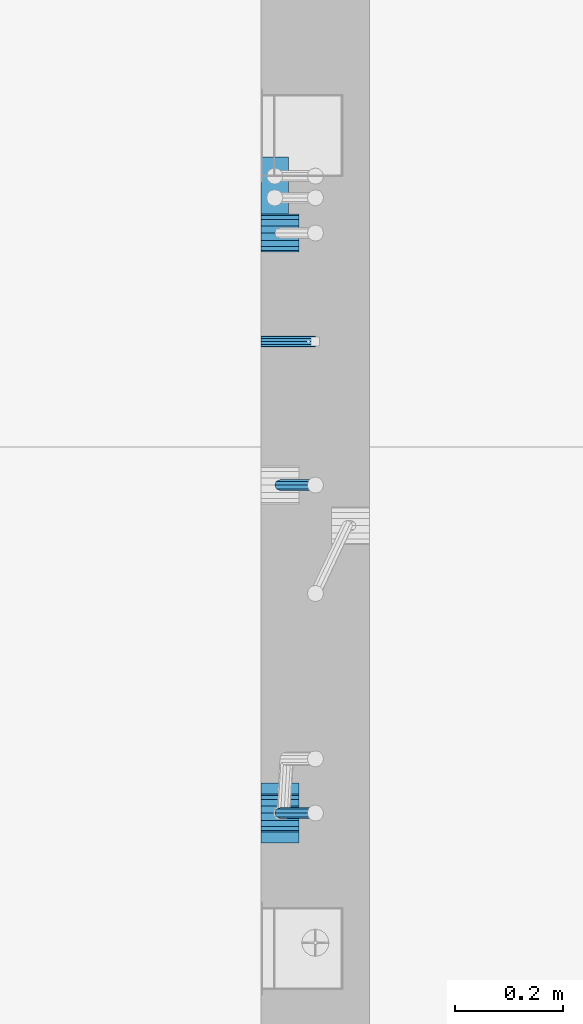
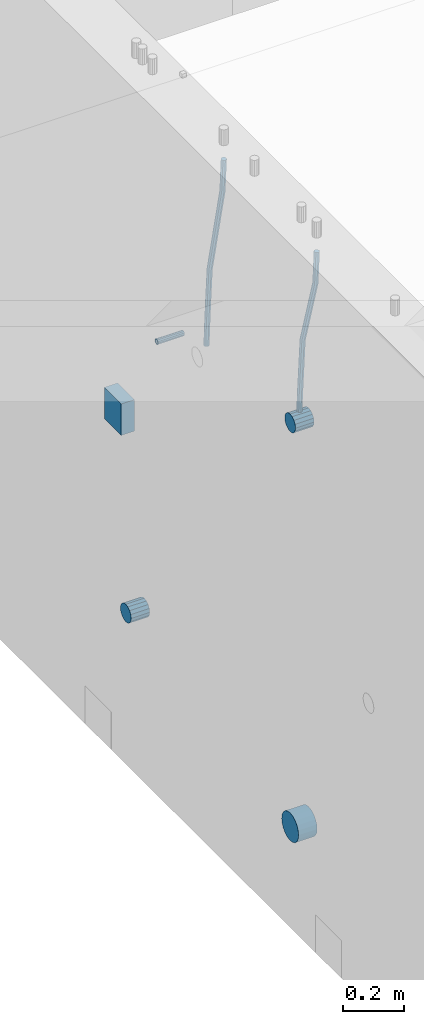
# One storey, part 140 of 341: 7 beams, 2 elements without a shape of their own.
"""IFC2X3 building model written with IfcOpenShell, lengths in millimetres."""

from ifc_helpers import new_model, si_unit, frame, origin_with_axes, place, context, subcontext, project, spatial, faceted_brep, material, type_object, element, aggregate, save


model = new_model("IFC2X3")

# Units and contexts
model_context = context("Model", 3, precision=1e-05, world=origin_with_axes())
body_context = subcontext(model_context, "Body", "Model", "MODEL_VIEW")
ifc_project = project(units=[si_unit("LENGTHUNIT", "METRE", prefix="MILLI"), si_unit("AREAUNIT", "SQUARE_METRE"), si_unit("VOLUMEUNIT", "CUBIC_METRE"), si_unit("MASSUNIT", "GRAM", prefix="KILO"), si_unit("TIMEUNIT", "SECOND"), si_unit("PLANEANGLEUNIT", "RADIAN"), si_unit("SOLIDANGLEUNIT", "STERADIAN"), si_unit("THERMODYNAMICTEMPERATUREUNIT", "DEGREE_CELSIUS"), si_unit("LUMINOUSINTENSITYUNIT", "LUMEN")], contexts=[model_context])

# Site, building, storey
site_placement = place(None, origin_with_axes())
site = spatial("IfcSite", under=ifc_project, at=site_placement, CompositionType="ELEMENT")
building_placement = place(site_placement, origin_with_axes())
building = spatial("IfcBuilding", under=site, at=building_placement, CompositionType="ELEMENT")
storey_placement = place(building_placement, origin_with_axes())
storey = spatial("IfcBuildingStorey", under=building, at=storey_placement, Name="5", CompositionType="ELEMENT", Elevation=0.0)

# Assemblies, beams
assembly_1_placement = place(storey_placement, origin_with_axes())
assembly_1 = element("IfcElementAssembly", 1, at=assembly_1_placement, inside=storey, AssemblyPlace="NOTDEFINED", PredefinedType="REINFORCEMENT_UNIT")
assembly_2_placement = place(assembly_1_placement, origin_with_axes())
assembly_2 = element("IfcElementAssembly", 2, at=assembly_2_placement, Name="Steel Assembly", AssemblyPlace="NOTDEFINED", PredefinedType="RIGID_FRAME")
ifc_material_1 = material(Name="STEEL/Steel_Undefined")
beam_type_1 = type_object("IfcBeamType", PredefinedType="NOTDEFINED")
beam_1_placement = place(assembly_2_placement, frame((21710.0, 11374.9997839591, 95555.0), z_axis=(0.0, 1.0, 0.0), x_axis=(1.0, 0.0, 0.0)))
beam_1 = element("IfcBeam", 3, at=beam_1_placement, type_object=beam_type_1, material=ifc_material_1, Name="M16", context=body_context, shape_type="Brep", body=[
    faceted_brep([(0.0, -8.49999999999272, -1.45519152283669e-11), (0.0, -7.36121593215648, 4.24999999998545), (100.000000000262, -7.36121593215648, 4.24999999998545), (100.000000000262, -8.49999999999272, -1.45519152283669e-11), (0.0, -4.24999999998545, 7.36121593216376), (100.000000000262, -4.24999999998545, 7.36121593216376), (0.0, 1.45519152283669e-11, 8.49999999998545), (100.000000000262, 1.45519152283669e-11, 8.49999999998545), (0.0, 4.25000000001455, 7.36121593216376), (100.000000000262, 4.25000000001455, 7.36121593216376), (0.0, 7.36121593217104, 4.24999999998545), (100.000000000262, 7.36121593217104, 4.24999999998545), (0.0, 8.50000000000728, 0.0), (100.000000000262, 8.50000000000728, 0.0), (0.0, 7.36121593217104, -4.25000000001455), (100.000000000262, 7.36121593217104, -4.25000000001455), (0.0, 4.25000000000728, -7.36121593219286), (100.000000000262, 4.25000000000728, -7.36121593219286), (0.0, 7.27595761418343e-12, -8.5), (100.000000000262, 7.27595761418343e-12, -8.5), (0.0, -4.24999999999272, -7.36121593217831), (100.000000000262, -4.24999999999272, -7.36121593217831), (0.0, -7.36121593215648, -4.25), (100.000000000262, -7.36121593215648, -4.25), (0.0, -10.4999999999927, -1.45519152283669e-11), (0.0, -9.09326673972828, -5.25000000001455), (100.000000000262, -9.09326673972828, -5.25000000001455), (100.000000000262, -10.4999999999927, -1.45519152283669e-11), (0.0, -5.24999999998545, -9.09326673974283), (100.000000000262, -5.24999999998545, -9.09326673974283), (0.0, 7.27595761418343e-12, -10.5), (100.000000000262, 7.27595761418343e-12, -10.5), (0.0, 5.25000000001455, -9.09326673975738), (100.000000000262, 5.25000000001455, -9.09326673975738), (0.0, 9.09326673975011, -5.25000000001455), (100.000000000262, 9.09326673975011, -5.25000000001455), (0.0, 10.5000000000073, -1.45519152283669e-11), (100.000000000262, 10.5000000000073, -1.45519152283669e-11), (0.0, 9.09326673975011, 5.25), (100.000000000262, 9.09326673975011, 5.25), (0.0, 5.25000000000728, 9.09326673972828), (100.000000000262, 5.25000000000728, 9.09326673972828), (0.0, 1.45519152283669e-11, 10.4999999999854), (100.000000000262, 1.45519152283669e-11, 10.4999999999854), (0.0, -5.24999999999272, 9.09326673972828), (100.000000000262, -5.24999999999272, 9.09326673972828), (0.0, -9.09326673972828, 5.24999999998545), (100.000000000262, -9.09326673972828, 5.24999999998545)], [[[0, 1, 2, 3]], [[1, 4, 5, 2]], [[4, 6, 7, 5]], [[6, 8, 9, 7]], [[8, 10, 11, 9]], [[10, 12, 13, 11]], [[12, 14, 15, 13]], [[14, 16, 17, 15]], [[16, 18, 19, 17]], [[18, 20, 21, 19]], [[20, 22, 23, 21]], [[22, 0, 3, 23]], [[24, 25, 26, 27]], [[25, 28, 29, 26]], [[28, 30, 31, 29]], [[30, 32, 33, 31]], [[32, 34, 35, 33]], [[34, 36, 37, 35]], [[36, 38, 39, 37]], [[38, 40, 41, 39]], [[40, 42, 43, 41]], [[42, 44, 45, 43]], [[44, 46, 47, 45]], [[46, 24, 27, 47]], [[29, 31, 33, 35, 37, 39, 41, 43, 45, 47, 27, 26], [5, 7, 9, 11, 13, 15, 17, 19, 21, 23, 3, 2]], [[46, 44, 42, 40, 38, 36, 34, 32, 30, 28, 25, 24], [22, 20, 18, 16, 14, 12, 10, 8, 6, 4, 1, 0]]]),
])
aggregate(assembly_2, [beam_1])
ifc_material_2 = material()
beam_type_2 = type_object("IfcBeamType", Name="D20", PredefinedType="NOTDEFINED")
beam_2_placement = place(assembly_1_placement, frame((21744.9999977209, 10504.9999999961, 95795.0), z_axis=(0.999642804629538, 0.000205762999925497, -0.0267249099901003), x_axis=(0.0267249109941254, -4.30000210532798e-08, 0.999642825779465)))
beam_2 = element("IfcBeam", 4, at=beam_2_placement, type_object=beam_type_2, material=ifc_material_2, Name="JM20", ObjectType="D20", context=body_context, shape_type="Brep", body=[
    faceted_brep([(0.0, -10.0, 0.0), (-4.19531716033816e-08, -7.07106781186667, -7.07106781187031), (60.3902110151248, -7.07106779622882, -7.07106780570393), (60.3902110191848, -9.99999998436397, 6.15546014159918e-09), (0.0, 0.0, -10.0), (60.3902110119234, 1.56360329128802e-08, -9.99999999383726), (4.196772351861e-08, 7.07106781186303, -7.07106781186667), (60.3902110114723, 7.07106782750088, -7.07106780570757), (0.0, 10.0, 0.0), (60.3902110140189, 10.000000015636, 6.15909812040627e-09), (4.196772351861e-08, 7.07106781185939, 7.07106781185939), (60.3902110180788, 7.07106782750088, 7.07106781802213), (0.0, 0.0, 10.0), (60.3902110212803, 1.56378519022837e-08, 10.0000000061627), (-4.19531716033816e-08, -7.07106781187031, 7.07106781185939), (60.3902110217459, -7.07106779622882, 7.07106781802213), (61.0636251037213, -7.07106779605601, -7.07106780563481), (60.991799419251, -9.99999998403655, 6.21366780251265e-09), (61.0933608038758, 1.58179318532348e-08, -9.99999999376814), (61.0635953103047, 7.07106782767551, -7.07106780563481), (60.9917724058905, 10.0000000159635, 6.21366780251265e-09), (60.9199467214348, 7.07106782763913, 7.07106781808034), (60.8902110212803, 1.57651811605319e-08, 10.0000000062137), (60.919976514866, -7.07106779609421, 7.07106781808034), (61.736900248201, -7.07106495914195, -7.05738882369405), (61.5932788141945, -9.99999744984598, 0.0122201548947487), (61.7963655163912, 2.97800033877138e-06, -9.98571699394597), (61.7368406711612, 7.07107066446406, -7.05738942880998), (61.5931945595512, 10.0000025499758, 0.0122192991293559), (61.4495731255302, 7.07107005927173, 7.0818282777218), (61.3901078573399, 2.12213126360439e-06, 10.0101564479701), (61.4496327025554, -7.07106556433428, 7.08182888283409), (278.724613209561, -7.07015065944142, -2.64883307638229), (278.580991775569, -9.99908315014545, 4.42077590220288), (278.78407847778, 0.000917277700864361, -5.57716124663784), (278.724553632535, 7.07198496416277, -2.64883368149822), (278.580907520925, 10.0009168496781, 4.42077504644112), (278.437286086933, 7.07198435897226, 11.4903840250299), (278.377820818714, 0.000916421833608183, 14.4187121952782), (278.437345663944, -7.07015126463193, 11.4903846301422), (280.757740145142, -7.07014209265617, -2.60752588292962), (279.97914288567, -9.99907725889352, 4.4491822438722), (281.080112136013, 0.000926952270674519, -5.53051255744504), (280.757417718196, 7.07199352984026, -2.60753182838744), (279.978686905117, 10.0009227393621, 4.44917383572465), (279.200089645645, 7.0719875731229, 11.5058819625192), (278.877717654759, 0.000918528197871638, 14.4288686370419), (279.200412072576, -7.07014804937353, 11.5058879079807), (282.750959243713, -7.07005867588668, -2.20455064874841), (281.349849970706, -9.99901989442333, 4.72630231008952), (283.331077414448, 0.00102115578738449, -5.07542798552822), (282.750379126286, 7.07207693582313, -2.20460869228191), (281.349029560777, 10.0009800885819, 4.72622022413998), (279.947920287756, 7.07201887003976, 11.6570731829706), (279.367802117034, 0.000939038367505418, 14.5279505197614), (279.948500405197, -7.07011674167188, 11.6571312265078), (490.42756900216, -7.06136735270411, 39.782068138702), (489.026459729153, -9.99032857123893, 46.7129210975436), (491.007687172896, 0.00971247897177818, 36.9111908019222), (490.426988884734, 7.08076825901298, 39.7820100951685), (489.02563931921, 10.0096714117662, 46.7128390115868), (487.624530046218, 7.08071019322961, 53.6436919704247), (487.044411875468, 0.0096303615537181, 56.5145693072081), (487.625110163644, -7.06142541848567, 53.6437500139618), (491.139936791646, -7.06133753991526, 39.9260897251916), (490.366909417033, -9.99027247305094, 46.9839239327412), (491.497771635157, 0.00973298914141196, 37.0102726846344), (491.230799149358, 7.08080189869361, 39.9445188880345), (490.495408195638, 10.0097329219989, 47.0099867047757), (489.722380821026, 7.08079798886138, 54.0678209123216), (489.3645459775, 0.00972745980288892, 56.9836379528824), (489.631518463313, -7.06134144974749, 54.0493917494787), (491.866591294849, -7.07081326331172, 39.9357607788479), (491.734242157807, -10.008102771757, 47.0021217808862), (491.997684863585, 0.00321401835935831, 37.0169260358998), (492.050730029368, 7.07010983225518, 39.955431358132), (491.994653653514, 9.99018245447223, 47.0299401808879), (491.862304516457, 7.05289294603062, 54.0963011829335), (491.731210947721, -0.0211343356422731, 57.0151359258853), (491.678165781937, -7.08803014953628, 54.0766306036494), (512.839658019177, -7.34430634461387, 40.2148915801045), (512.707308882134, -10.2815958530537, 47.2812525821391), (512.970751587927, -0.270279062942791, 37.2960568371527), (513.023796753681, 6.79661675095485, 40.2345621593813), (512.967720377841, 9.7166893731719, 47.3090709821408), (512.835371240784, 6.77939986473211, 54.3754319841792), (512.704277672048, -0.294627416940784, 57.2942667271309), (512.651232506279, -7.36152323083843, 54.3557614048987), (513.475023168634, -7.35259163615956, 40.2233476626352), (513.367394028246, -10.2902034984181, 47.2900376634097), (513.548964110931, -0.277819072547572, 37.3037522746854), (513.54590325398, 6.78980837536619, 40.2415108811765), (513.467633606255, 9.71017040238803, 47.3157243334063), (513.360004465882, 6.77255854013129, 54.3824143341844), (513.28606352357, -0.302214023480701, 57.3020097221342), (513.289124380535, -7.36984147139265, 54.3642511156468), (514.110442121717, -7.35071708105352, 40.2316099536038), (514.027534909808, -10.2882349910469, 47.298629034136), (514.127225867254, -0.276123320652914, 37.311252921696), (514.068054455944, 6.79134521359629, 40.248263480742), (513.967589697961, 9.71166130597521, 47.3221806780894), (513.884682486052, 6.77414339598363, 54.3891997586288), (513.8678987405, -0.300450364420612, 57.309556790533), (513.927070151825, -7.36791889866981, 54.3725462314869), (614.131230002764, -7.05245493793518, 41.5289880054152), (614.048322790841, -9.98997284792858, 48.596007085951), (614.148013748316, 0.022138822467241, 38.608630973511), (614.088842336976, 7.08960735671644, 41.5456415325607), (613.988377579022, 10.0099234490935, 48.6195587299044), (613.905470367114, 7.07240553910196, 55.6865778104475), (613.888686621562, -0.00218822130045737, 58.6069348423516), (613.947858032887, -7.06965675554966, 55.6699242832983)], [[[0, 1, 2, 3]], [[1, 4, 5, 2]], [[4, 6, 7, 5]], [[6, 8, 9, 7]], [[8, 10, 11, 9]], [[10, 12, 13, 11]], [[12, 14, 15, 13]], [[14, 0, 3, 15]], [[14, 12, 10, 8, 6, 4, 1, 0]], [[3, 2, 16, 17]], [[2, 5, 18, 16]], [[5, 7, 19, 18]], [[7, 9, 20, 19]], [[9, 11, 21, 20]], [[11, 13, 22, 21]], [[13, 15, 23, 22]], [[15, 3, 17, 23]], [[17, 16, 24, 25]], [[16, 18, 26, 24]], [[18, 19, 27, 26]], [[19, 20, 28, 27]], [[20, 21, 29, 28]], [[21, 22, 30, 29]], [[22, 23, 31, 30]], [[23, 17, 25, 31]], [[25, 24, 32, 33]], [[24, 26, 34, 32]], [[26, 27, 35, 34]], [[27, 28, 36, 35]], [[28, 29, 37, 36]], [[29, 30, 38, 37]], [[30, 31, 39, 38]], [[31, 25, 33, 39]], [[33, 32, 40, 41]], [[32, 34, 42, 40]], [[34, 35, 43, 42]], [[35, 36, 44, 43]], [[36, 37, 45, 44]], [[37, 38, 46, 45]], [[38, 39, 47, 46]], [[39, 33, 41, 47]], [[41, 40, 48, 49]], [[40, 42, 50, 48]], [[42, 43, 51, 50]], [[43, 44, 52, 51]], [[44, 45, 53, 52]], [[45, 46, 54, 53]], [[46, 47, 55, 54]], [[47, 41, 49, 55]], [[49, 48, 56, 57]], [[48, 50, 58, 56]], [[50, 51, 59, 58]], [[51, 52, 60, 59]], [[52, 53, 61, 60]], [[53, 54, 62, 61]], [[54, 55, 63, 62]], [[55, 49, 57, 63]], [[57, 56, 64, 65]], [[56, 58, 66, 64]], [[58, 59, 67, 66]], [[59, 60, 68, 67]], [[60, 61, 69, 68]], [[61, 62, 70, 69]], [[62, 63, 71, 70]], [[63, 57, 65, 71]], [[65, 64, 72, 73]], [[64, 66, 74, 72]], [[66, 67, 75, 74]], [[67, 68, 76, 75]], [[68, 69, 77, 76]], [[69, 70, 78, 77]], [[70, 71, 79, 78]], [[71, 65, 73, 79]], [[73, 72, 80, 81]], [[72, 74, 82, 80]], [[74, 75, 83, 82]], [[75, 76, 84, 83]], [[76, 77, 85, 84]], [[77, 78, 86, 85]], [[78, 79, 87, 86]], [[79, 73, 81, 87]], [[81, 80, 88, 89]], [[80, 82, 90, 88]], [[82, 83, 91, 90]], [[83, 84, 92, 91]], [[84, 85, 93, 92]], [[85, 86, 94, 93]], [[86, 87, 95, 94]], [[87, 81, 89, 95]], [[89, 88, 96, 97]], [[88, 90, 98, 96]], [[90, 91, 99, 98]], [[91, 92, 100, 99]], [[92, 93, 101, 100]], [[93, 94, 102, 101]], [[94, 95, 103, 102]], [[95, 89, 97, 103]], [[97, 96, 104, 105]], [[96, 98, 106, 104]], [[98, 99, 107, 106]], [[99, 100, 108, 107]], [[100, 101, 109, 108]], [[101, 102, 110, 109]], [[102, 103, 111, 110]], [[103, 97, 105, 111]], [[106, 107, 108, 109, 110, 111, 105, 104]]]),
])
beam_3_placement = place(assembly_1_placement, frame((21744.9999977209, 11109.9999999961, 95690.0), z_axis=(0.999642804629538, 0.000205762999925497, -0.0267249099901003), x_axis=(0.0267249109941254, -4.30000210532798e-08, 0.999642825779465)))
beam_3 = element("IfcBeam", 5, at=beam_3_placement, type_object=beam_type_2, material=ifc_material_2, Name="JM20", ObjectType="D20", context=body_context, shape_type="Brep", body=[
    faceted_brep([(0.0, -10.0, 0.0), (-4.19531716033816e-08, -7.07106781186667, -7.07106781187031), (60.4266690400545, -7.0710677960451, -7.07106780570757), (60.4266690441291, -9.99999998418934, 6.15546014159918e-09), (0.0, 0.0, -10.0), (60.426669036824, 1.58106558956206e-08, -9.99999999384454), (4.196772351861e-08, 7.07106781186303, -7.07106781186667), (60.4266690363438, 7.07106782768096, -7.07106780570757), (0.0, 10.0, 0.0), (60.4266690388904, 10.0000000158179, 6.15182216279209e-09), (4.196772351861e-08, 7.07106781185939, 7.07106781185939), (60.4266690429649, 7.07106782768096, 7.07106781802577), (0.0, 0.0, 10.0), (60.4266690461809, 1.58179318532348e-08, 10.0000000061555), (-4.19531716033816e-08, -7.07106781187031, 7.07106781185939), (60.4266690466611, -7.07106779605238, 7.07106781802213), (61.0378400410118, -7.07106779588503, -7.07106780564936), (60.991799419251, -9.99999998403655, 6.21366780251265e-09), (61.0569027789461, 1.5985278878361e-08, -9.99999999378269), (61.0378209396877, 7.07106782784831, -7.07106780564936), (60.9917724058905, 10.0000000159635, 6.21366780251265e-09), (60.9457317841297, 7.07106782781193, 7.0710678180767), (60.9266690461809, 1.59488990902901e-08, 10.0000000062028), (60.9457508854539, -7.07106779591413, 7.0710678180767), (61.6489592143771, -7.07106614513759, -7.06310863441468), (61.5568818710308, -9.9999984576425, 0.00735959856683621), (61.6870830769039, 1.71821739058942e-06, -9.99179257185824), (61.6489210170112, 7.07106947854481, -7.06310888312146), (61.556827851804, 10.0000015422847, 0.00735924683976918), (61.4647505084577, 7.07106922979438, 7.07782747982128), (61.4266266459163, 1.36643211590126e-06, 10.0065114172685), (61.464788705809, -7.07106639389531, 7.07782772852806), (176.543135720174, -7.07075579406956, -5.56673531796696), (176.451058376813, -9.99968810657447, 1.50373291501455), (176.581259582701, 0.000312069292704109, -8.49541925541052), (176.543097522794, 7.07137982961285, -5.56673556667374), (176.451004357587, 10.00031189336, 1.50373256329476), (176.35892701424, 7.07137958085514, 8.57420079627263), (176.320803151699, 0.000311717507429421, 11.5028847337162), (176.358965211621, -7.07075604281999, 8.57420104497578), (177.098753836006, -7.07075429323595, -5.55949898843028), (176.98362511232, -9.99968666800123, 1.510669025065), (177.146421932586, 0.000313595905026887, -8.48805862247536), (177.098706077581, 7.07138133041735, -5.55949936166144), (176.983557571715, 10.0003133318824, 1.51066849724157), (176.868428848029, 7.07138095712435, 8.58083651073321), (176.820760751449, 0.000313067976094317, 11.5093961447819), (176.868476606425, -7.07075466652896, 8.58083688396073), (177.654312950661, -7.07075204110879, -5.54863964998367), (177.516135294456, -9.99968450931192, 1.52107783331303), (177.711524267797, 0.000315886711177882, -8.47701274570863), (177.654255632195, 7.07138358250813, -5.54864021007961), (177.516054233929, 10.0003154905207, 1.5210770412159), (177.377876577739, 7.0713830223176, 8.59079452451624), (177.320665260588, 0.000315094497636892, 11.5191676202448), (177.377933896176, -7.07075260129932, 8.59079508461218), (299.029771459231, -7.07026000924998, -3.17615191846562), (298.89159380304, -9.99919247745311, 3.89356556482744), (299.086982776382, 0.00080791857362783, -6.10452501419059), (299.029714140794, 7.07187561436331, -3.1761524785652), (298.891512742513, 10.0008075223832, 3.89356477273031), (298.753335086294, 7.07187505418005, 10.963282256027), (298.696123769172, 0.000807126352810883, 13.891655351752), (298.75339240476, -7.07026056943323, 10.963282816123), (300.5204182054, -7.07025396646532, -3.14701471758235), (299.971932015731, -9.99918809797782, 3.91468259446992), (300.747514543924, 0.000814650038591935, -6.07206712448169), (300.520191076153, 7.07188165646039, -3.14701859691559), (299.971610806504, 10.0008119008835, 3.91467710826691), (299.423124616849, 7.0718777693728, 10.9763744203192), (299.196028278326, 0.000809152865258511, 13.9014268272185), (299.423351746067, -7.0702578535529, 10.9763782996524), (301.997683885507, -7.07021227996847, -2.94561261413764), (301.042572372782, -9.99915788591352, 4.06064768581928), (302.393140241125, 0.000861087435623631, -5.84771176216236), (301.997288469822, 7.07192333820967, -2.94563943669345), (301.042013170576, 10.0008421062339, 4.0606097529926), (300.086901657865, 7.07189650029068, 11.0668700529459), (299.691445302247, 0.000823132886580424, 13.9689692009706), (300.087297073522, -7.07023911788747, 11.066896875509), (595.247547294217, -7.06193715364316, 37.0344262651415), (594.292435781506, -9.99088275958638, 44.0406865650948), (595.643003649835, 0.00913621376093943, 34.1323271171168), (595.247151878561, 7.08019846453499, 37.0343994425784), (594.291876579315, 10.0091172325574, 44.0406486322681), (593.336765066575, 7.08017162661235, 51.0469089322251), (592.941308710972, 0.00909825921189622, 53.9490080802498), (593.337160482261, -7.06196399156397, 51.0469357547881), (595.874536898147, -7.0619194608189, 37.1199065052715), (595.328959329563, -9.99085351025315, 44.1820003623798), (596.138420673757, 0.00915019377680437, 34.1998694908689), (595.966031119533, 7.08021875036138, 37.132407399582), (595.458351698282, 10.0091501489569, 44.1996792966529), (594.912774129698, 7.08021609952084, 51.2617731537612), (594.648890354089, 0.00914644492513617, 54.1818101681638), (594.821279908327, -7.06192211166126, 51.2492722594543), (596.507216806087, -7.07016973634745, 37.1283268498955), (596.374889946004, -10.0044926596274, 44.1959206657302), (596.638333902185, 0.00263122293472406, 34.2065228421343), (596.691434617649, 7.07075934023669, 37.1420618035991), (596.635413273558, 9.99380102503346, 44.2153448235404), (596.503086413475, 7.05947810175894, 51.2829386393751), (596.371969317406, -0.0133228575232351, 54.2047426471363), (596.318868601928, -7.08145097482702, 51.2692036856752), (617.802075790198, -7.34785905717763, 37.4117403882592), (617.669748930144, -10.282181980454, 44.4793342040939), (617.933192886281, -0.275058097895453, 34.4899363805016), (617.98629360176, 6.79307001940651, 37.4254753419664), (617.930272257669, 9.7161117042051, 44.498758361904), (617.797945397615, 6.78178878092876, 51.5663521777387), (617.666828301532, -0.291012178353412, 54.4881561855073), (617.613727586038, -7.35914029565538, 51.5526172240352), (618.437465979412, -7.3561446753265, 37.4201968040506), (618.329835563593, -10.2907896452944, 44.488119305166), (618.51143976918, -0.28259855563374, 34.4976322753282), (618.508424090105, 6.78626133094076, 37.4324243830088), (618.430185486082, 9.70959273336121, 44.5054117131695), (618.322555070263, 6.77494776339336, 51.5733342142812), (618.248581280495, -0.298598356299408, 54.4958987430036), (618.25159695957, -7.36745824287755, 51.5611066353231), (619.072909978044, -7.35426965608167, 37.428459048002), (618.989977939549, -10.2888211210229, 44.4967101569127), (619.089735886533, -0.2809021629364, 34.5051333804877), (619.030599275982, 6.78779861257681, 37.4391776831617), (618.930141570861, 9.7110836245156, 44.5118685961243), (618.847209532338, 6.77653215957434, 51.5801197050387), (618.830383623877, -0.296835333569106, 54.503445372553), (618.889520234414, -7.36553610908049, 51.569401069879), (719.093697115357, -7.05600751202655, 38.7258370901727), (719.010765076877, -9.9905589769678, 45.7940881990799), (719.110523023846, 0.017359981116897, 35.8025114226548), (719.051386413325, 7.08606075662829, 38.7365557253288), (718.950928708175, 10.0093457685707, 45.809246638295), (718.86799666968, 7.07479430362946, 52.8774977472058), (718.851170761191, 0.00142681048419036, 55.8008234147201), (718.910307371727, -7.06727396502902, 52.8667791120424)], [[[0, 1, 2, 3]], [[1, 4, 5, 2]], [[4, 6, 7, 5]], [[6, 8, 9, 7]], [[8, 10, 11, 9]], [[10, 12, 13, 11]], [[12, 14, 15, 13]], [[14, 0, 3, 15]], [[14, 12, 10, 8, 6, 4, 1, 0]], [[3, 2, 16, 17]], [[2, 5, 18, 16]], [[5, 7, 19, 18]], [[7, 9, 20, 19]], [[9, 11, 21, 20]], [[11, 13, 22, 21]], [[13, 15, 23, 22]], [[15, 3, 17, 23]], [[17, 16, 24, 25]], [[16, 18, 26, 24]], [[18, 19, 27, 26]], [[19, 20, 28, 27]], [[20, 21, 29, 28]], [[21, 22, 30, 29]], [[22, 23, 31, 30]], [[23, 17, 25, 31]], [[25, 24, 32, 33]], [[24, 26, 34, 32]], [[26, 27, 35, 34]], [[27, 28, 36, 35]], [[28, 29, 37, 36]], [[29, 30, 38, 37]], [[30, 31, 39, 38]], [[31, 25, 33, 39]], [[33, 32, 40, 41]], [[32, 34, 42, 40]], [[34, 35, 43, 42]], [[35, 36, 44, 43]], [[36, 37, 45, 44]], [[37, 38, 46, 45]], [[38, 39, 47, 46]], [[39, 33, 41, 47]], [[41, 40, 48, 49]], [[40, 42, 50, 48]], [[42, 43, 51, 50]], [[43, 44, 52, 51]], [[44, 45, 53, 52]], [[45, 46, 54, 53]], [[46, 47, 55, 54]], [[47, 41, 49, 55]], [[49, 48, 56, 57]], [[48, 50, 58, 56]], [[50, 51, 59, 58]], [[51, 52, 60, 59]], [[52, 53, 61, 60]], [[53, 54, 62, 61]], [[54, 55, 63, 62]], [[55, 49, 57, 63]], [[57, 56, 64, 65]], [[56, 58, 66, 64]], [[58, 59, 67, 66]], [[59, 60, 68, 67]], [[60, 61, 69, 68]], [[61, 62, 70, 69]], [[62, 63, 71, 70]], [[63, 57, 65, 71]], [[65, 64, 72, 73]], [[64, 66, 74, 72]], [[66, 67, 75, 74]], [[67, 68, 76, 75]], [[68, 69, 77, 76]], [[69, 70, 78, 77]], [[70, 71, 79, 78]], [[71, 65, 73, 79]], [[73, 72, 80, 81]], [[72, 74, 82, 80]], [[74, 75, 83, 82]], [[75, 76, 84, 83]], [[76, 77, 85, 84]], [[77, 78, 86, 85]], [[78, 79, 87, 86]], [[79, 73, 81, 87]], [[81, 80, 88, 89]], [[80, 82, 90, 88]], [[82, 83, 91, 90]], [[83, 84, 92, 91]], [[84, 85, 93, 92]], [[85, 86, 94, 93]], [[86, 87, 95, 94]], [[87, 81, 89, 95]], [[89, 88, 96, 97]], [[88, 90, 98, 96]], [[90, 91, 99, 98]], [[91, 92, 100, 99]], [[92, 93, 101, 100]], [[93, 94, 102, 101]], [[94, 95, 103, 102]], [[95, 89, 97, 103]], [[97, 96, 104, 105]], [[96, 98, 106, 104]], [[98, 99, 107, 106]], [[99, 100, 108, 107]], [[100, 101, 109, 108]], [[101, 102, 110, 109]], [[102, 103, 111, 110]], [[103, 97, 105, 111]], [[105, 104, 112, 113]], [[104, 106, 114, 112]], [[106, 107, 115, 114]], [[107, 108, 116, 115]], [[108, 109, 117, 116]], [[109, 110, 118, 117]], [[110, 111, 119, 118]], [[111, 105, 113, 119]], [[113, 112, 120, 121]], [[112, 114, 122, 120]], [[114, 115, 123, 122]], [[115, 116, 124, 123]], [[116, 117, 125, 124]], [[117, 118, 126, 125]], [[118, 119, 127, 126]], [[119, 113, 121, 127]], [[121, 120, 128, 129]], [[120, 122, 130, 128]], [[122, 123, 131, 130]], [[123, 124, 132, 131]], [[124, 125, 133, 132]], [[125, 126, 134, 133]], [[126, 127, 135, 134]], [[127, 121, 129, 135]], [[130, 131, 132, 133, 134, 135, 129, 128]]]),
])
beam_type_3 = type_object("IfcBeamType", Name="D70", PredefinedType="NOTDEFINED")
beam_4_placement = place(assembly_1_placement, frame((21709.9999977209, 10505.0, 95760.0), z_axis=(0.0, 0.0, 1.0), x_axis=(1.0, 0.0, 0.0)))
beam_4 = element("IfcBeam", 6, at=beam_4_placement, type_object=beam_type_3, material=ifc_material_2, ObjectType="D70", context=body_context, shape_type="Brep", body=[
    faceted_brep([(0.0, -35.0, 0.0), (0.0, -32.3357836378964, -13.3939201327739), (70.0, -32.3357836378964, -13.3939201327739), (70.0, -35.0, 0.0), (0.0, -24.7487373415279, -24.7487373415352), (70.0, -24.7487373415279, -24.7487373415352), (0.0, -13.3939201327776, -32.3357836379), (70.0, -13.3939201327776, -32.3357836379), (0.0, 0.0, -35.0), (70.0, 0.0, -35.0), (0.0, 13.3939201327776, -32.3357836379), (70.0, 13.3939201327776, -32.3357836379), (0.0, 24.7487373415279, -24.7487373415352), (70.0, 24.7487373415279, -24.7487373415352), (0.0, 32.3357836378964, -13.3939201327739), (70.0, 32.3357836378964, -13.3939201327739), (0.0, 35.0, 0.0), (70.0, 35.0, 0.0), (0.0, 32.3357836378964, 13.3939201327739), (70.0, 32.3357836378964, 13.3939201327739), (0.0, 24.7487373415279, 24.7487373415352), (70.0, 24.7487373415279, 24.7487373415352), (0.0, 13.3939201327776, 32.3357836379), (70.0, 13.3939201327776, 32.3357836379), (0.0, 0.0, 35.0), (70.0, 0.0, 35.0), (0.0, -13.3939201327776, 32.3357836379), (70.0, -13.3939201327776, 32.3357836379), (0.0, -24.7487373415279, 24.7487373415352), (70.0, -24.7487373415279, 24.7487373415352), (0.0, -32.3357836378964, 13.3939201327739), (70.0, -32.3357836378964, 13.3939201327739)], [[[0, 1, 2, 3]], [[1, 4, 5, 2]], [[4, 6, 7, 5]], [[6, 8, 9, 7]], [[8, 10, 11, 9]], [[10, 12, 13, 11]], [[12, 14, 15, 13]], [[14, 16, 17, 15]], [[16, 18, 19, 17]], [[18, 20, 21, 19]], [[20, 22, 23, 21]], [[22, 24, 25, 23]], [[24, 26, 27, 25]], [[26, 28, 29, 27]], [[28, 30, 31, 29]], [[30, 0, 3, 31]], [[5, 7, 9, 11, 13, 15, 17, 19, 21, 23, 25, 27, 29, 31, 3, 2]], [[30, 28, 26, 24, 22, 20, 18, 16, 14, 12, 10, 8, 6, 4, 1, 0]]]),
])
beam_5_placement = place(assembly_1_placement, frame((21709.9999977209, 11575.0, 94355.0), z_axis=(0.0, 0.0, 1.0), x_axis=(1.0, 0.0, 0.0)))
beam_5 = element("IfcBeam", 7, at=beam_5_placement, type_object=beam_type_3, material=ifc_material_2, ObjectType="D70", context=body_context, shape_type="Brep", body=[
    faceted_brep([(0.0, -35.0, 0.0), (0.0, -32.3357836378964, -13.3939201327739), (70.0, -32.3357836378964, -13.3939201327739), (70.0, -35.0, 0.0), (0.0, -24.7487373415279, -24.7487373415352), (70.0, -24.7487373415279, -24.7487373415352), (0.0, -13.3939201327776, -32.3357836379), (70.0, -13.3939201327776, -32.3357836379), (0.0, 0.0, -35.0), (70.0, 0.0, -35.0), (0.0, 13.3939201327776, -32.3357836379), (70.0, 13.3939201327776, -32.3357836379), (0.0, 24.7487373415279, -24.7487373415352), (70.0, 24.7487373415279, -24.7487373415352), (0.0, 32.3357836378964, -13.3939201327739), (70.0, 32.3357836378964, -13.3939201327739), (0.0, 35.0, 0.0), (70.0, 35.0, 0.0), (0.0, 32.3357836378964, 13.3939201327739), (70.0, 32.3357836378964, 13.3939201327739), (0.0, 24.7487373415279, 24.7487373415352), (70.0, 24.7487373415279, 24.7487373415352), (0.0, 13.3939201327776, 32.3357836379), (70.0, 13.3939201327776, 32.3357836379), (0.0, 0.0, 35.0), (70.0, 0.0, 35.0), (0.0, -13.3939201327776, 32.3357836379), (70.0, -13.3939201327776, 32.3357836379), (0.0, -24.7487373415279, 24.7487373415352), (70.0, -24.7487373415279, 24.7487373415352), (0.0, -32.3357836378964, 13.3939201327739), (70.0, -32.3357836378964, 13.3939201327739)], [[[0, 1, 2, 3]], [[1, 4, 5, 2]], [[4, 6, 7, 5]], [[6, 8, 9, 7]], [[8, 10, 11, 9]], [[10, 12, 13, 11]], [[12, 14, 15, 13]], [[14, 16, 17, 15]], [[16, 18, 19, 17]], [[18, 20, 21, 19]], [[20, 22, 23, 21]], [[22, 24, 25, 23]], [[24, 26, 27, 25]], [[26, 28, 29, 27]], [[28, 30, 31, 29]], [[30, 0, 3, 31]], [[5, 7, 9, 11, 13, 15, 17, 19, 21, 23, 25, 27, 29, 31, 3, 2]], [[30, 28, 26, 24, 22, 20, 18, 16, 14, 12, 10, 8, 6, 4, 1, 0]]]),
])
beam_type_4 = type_object("IfcBeamType", Name="D110", PredefinedType="NOTDEFINED")
beam_6_placement = place(assembly_1_placement, frame((21709.9999977209, 10505.0, 94155.0), z_axis=(0.0, 0.0, 1.0), x_axis=(1.0, 0.0, 0.0)))
beam_6 = element("IfcBeam", 8, at=beam_6_placement, type_object=beam_type_4, material=ifc_material_2, ObjectType="D110", context=body_context, shape_type="Brep", body=[
    faceted_brep([(0.0, -55.0, 0.0), (0.0, -52.3081083962352, -16.9959346906253), (70.0, -52.3081083962352, -16.9959346906253), (70.0, -55.0, 0.0), (0.0, -44.4959346906217, -32.328188876083), (70.0, -44.4959346906217, -32.328188876083), (0.0, -32.3281888760866, -44.4959346906253), (70.0, -32.3281888760866, -44.4959346906253), (0.0, -16.9959346906217, -52.3081083962315), (70.0, -16.9959346906217, -52.3081083962315), (0.0, 0.0, -55.0), (70.0, 0.0, -55.0), (0.0, 16.9959346906217, -52.3081083962315), (70.0, 16.9959346906217, -52.3081083962315), (0.0, 32.3281888760866, -44.4959346906253), (70.0, 32.3281888760866, -44.4959346906253), (0.0, 44.4959346906217, -32.328188876083), (70.0, 44.4959346906217, -32.328188876083), (0.0, 52.3081083962352, -16.9959346906253), (70.0, 52.3081083962352, -16.9959346906253), (0.0, 55.0, 0.0), (70.0, 55.0, 0.0), (0.0, 52.3081083962352, 16.9959346906253), (70.0, 52.3081083962352, 16.9959346906253), (0.0, 44.4959346906217, 32.328188876083), (70.0, 44.4959346906217, 32.328188876083), (0.0, 32.3281888760866, 44.4959346906253), (70.0, 32.3281888760866, 44.4959346906253), (0.0, 16.9959346906217, 52.3081083962315), (70.0, 16.9959346906217, 52.3081083962315), (0.0, 0.0, 55.0), (70.0, 0.0, 55.0), (0.0, -16.9959346906217, 52.3081083962315), (70.0, -16.9959346906217, 52.3081083962315), (0.0, -32.3281888760866, 44.4959346906253), (70.0, -32.3281888760866, 44.4959346906253), (0.0, -44.4959346906217, 32.328188876083), (70.0, -44.4959346906217, 32.328188876083), (0.0, -52.3081083962352, 16.9959346906253), (70.0, -52.3081083962352, 16.9959346906253)], [[[0, 1, 2, 3]], [[1, 4, 5, 2]], [[4, 6, 7, 5]], [[6, 8, 9, 7]], [[8, 10, 11, 9]], [[10, 12, 13, 11]], [[12, 14, 15, 13]], [[14, 16, 17, 15]], [[16, 18, 19, 17]], [[18, 20, 21, 19]], [[20, 22, 23, 21]], [[22, 24, 25, 23]], [[24, 26, 27, 25]], [[26, 28, 29, 27]], [[28, 30, 31, 29]], [[30, 32, 33, 31]], [[32, 34, 35, 33]], [[34, 36, 37, 35]], [[36, 38, 39, 37]], [[38, 0, 3, 39]], [[5, 7, 9, 11, 13, 15, 17, 19, 21, 23, 25, 27, 29, 31, 33, 35, 37, 39, 3, 2]], [[38, 36, 34, 32, 30, 28, 26, 24, 22, 20, 18, 16, 14, 12, 10, 8, 6, 4, 1, 0]]]),
])
beam_type_5 = type_object("IfcBeamType", Name="125X50", PredefinedType="NOTDEFINED")
beam_7_placement = place(assembly_1_placement, frame((21735.0, 11715.0, 95105.0), z_axis=(0.0, 0.0, 1.0), x_axis=(0.0, -1.0, 0.0)))
beam_7 = element("IfcBeam", 9, at=beam_7_placement, type_object=beam_type_5, material=ifc_material_2, Name="WM2", ObjectType="125X50", context=body_context, shape_type="Brep", body=[
    faceted_brep([(0.0, 25.0, -62.5), (0.0, 25.0, 62.5), (110.0, 25.0, 62.5), (110.0, 25.0, -62.5), (0.0, -25.0, 62.5), (110.0, -25.0, 62.5), (0.0, -25.0, -62.5), (110.0, -25.0, -62.5)], [[[0, 1, 2, 3]], [[1, 4, 5, 2]], [[4, 6, 7, 5]], [[6, 0, 3, 7]], [[5, 7, 3, 2]], [[0, 6, 4, 1]]]),
])
aggregate(assembly_1, [beam_2, beam_4, assembly_2, beam_7, beam_5, beam_3, beam_6])

save(model, "model.ifc")
